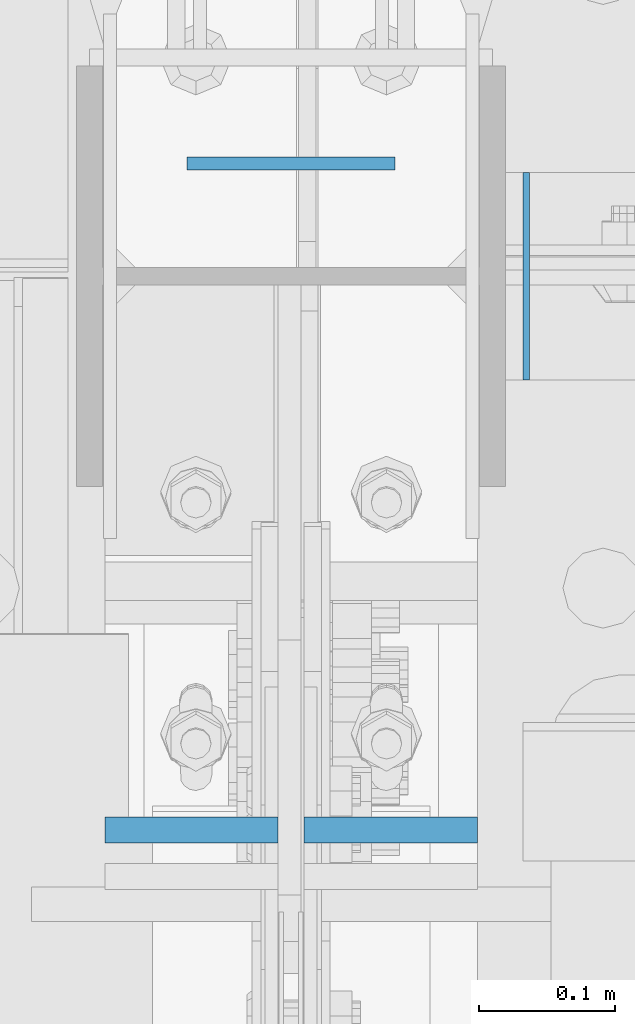
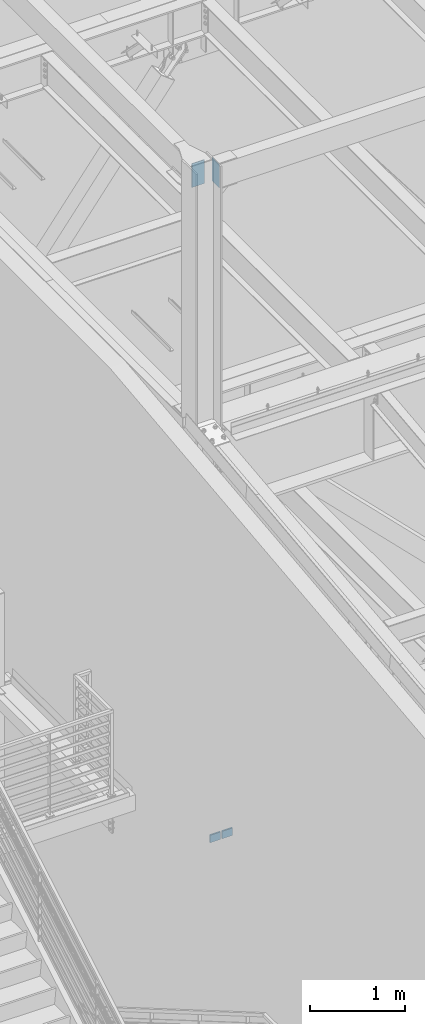
# One storey, part 489 of 1179: 4 columns, 4 elements without a shape of their own.
"""IFC2X3 building model written with IfcOpenShell, lengths in millimetres."""

from ifc_helpers import new_model, si_unit, frame, origin_with_axes, place, context, subcontext, project, spatial, faceted_brep, material, type_object, element, aggregate, save


model = new_model("IFC2X3")

# Units and contexts
model_context = context("Model", 3, precision=1e-05, world=origin_with_axes())
body_context = subcontext(model_context, "Body", "Model", "MODEL_VIEW")
ifc_project = project(units=[si_unit("LENGTHUNIT", "METRE", prefix="MILLI"), si_unit("AREAUNIT", "SQUARE_METRE"), si_unit("VOLUMEUNIT", "CUBIC_METRE"), si_unit("MASSUNIT", "GRAM", prefix="KILO"), si_unit("TIMEUNIT", "SECOND"), si_unit("PLANEANGLEUNIT", "RADIAN"), si_unit("SOLIDANGLEUNIT", "STERADIAN"), si_unit("THERMODYNAMICTEMPERATUREUNIT", "DEGREE_CELSIUS"), si_unit("LUMINOUSINTENSITYUNIT", "LUMEN")], contexts=[model_context])

# Site, building, storey
site_placement = place(None, origin_with_axes())
site = spatial("IfcSite", under=ifc_project, at=site_placement, CompositionType="ELEMENT")
building_placement = place(site_placement, origin_with_axes())
building = spatial("IfcBuilding", under=site, at=building_placement, Name="Undefined", CompositionType="ELEMENT")
storey_placement = place(building_placement, origin_with_axes())
storey = spatial("IfcBuildingStorey", under=building, at=storey_placement, Name="Undefined", CompositionType="ELEMENT", Elevation=0.0)

# Assembly, column
assembly_1_placement = place(storey_placement, origin_with_axes())
assembly_1 = element("IfcElementAssembly", 1, at=assembly_1_placement, inside=storey, Name="BEAM", AssemblyPlace="NOTDEFINED", PredefinedType="RIGID_FRAME")
ifc_material_1 = material(Name="STEEL/A36")
column_type_1 = type_object("IfcColumnType", PredefinedType="NOTDEFINED")
column_1_placement = place(assembly_1_placement, frame((431.8, 34474.1500000406, 16122.65), z_axis=(1.0, 0.0, 0.0), x_axis=(0.0, 0.0, 1.0)))
column_1 = element("IfcColumn", 2, at=column_1_placement, type_object=column_type_1, material=ifc_material_1, Name="PLATE", context=body_context, shape_type="Brep", body=[
    faceted_brep([(0.0, 4.76249999999982, -76.1999999999971), (0.0, 4.76249999999982, 76.1999999999971), (304.799999999999, 4.76250000000073, 76.1999999999971), (304.799999999999, 4.76250000000073, -76.1999999999971), (0.0, -4.76249999999982, 76.1999999999971), (304.799999999999, -4.76250000000073, 76.1999999999971), (0.0, -4.76249999999982, -76.1999999999971), (304.799999999999, -4.76250000000073, -76.1999999999971)], [[[0, 1, 2, 3]], [[1, 4, 5, 2]], [[4, 6, 7, 5]], [[6, 0, 3, 7]], [[5, 7, 3, 2]], [[6, 4, 1, 0]]]),
])
aggregate(assembly_1, [column_1])

assembly_2_placement = place(storey_placement, origin_with_axes())
assembly_2 = element("IfcElementAssembly", 3, at=assembly_2_placement, inside=storey, Name="PLATE", AssemblyPlace="NOTDEFINED", PredefinedType="RIGID_FRAME")
ifc_material_2 = material(Name="STEEL/A572-GR.50")
column_type_2 = type_object("IfcColumnType", PredefinedType="NOTDEFINED")
column_2_placement = place(assembly_2_placement, frame((358.774999999999, 33985.8157935486, 8013.69998747746), z_axis=(-1.0, 0.0, 0.0), x_axis=(0.0, 0.0, 1.0)))
column_2 = element("IfcColumn", 4, at=column_2_placement, type_object=column_type_2, material=ifc_material_2, Name="PLATE", context=body_context, shape_type="Brep", body=[
    faceted_brep([(0.0, 9.52500000000146, -63.5), (0.0, 9.52500000000146, 63.5), (96.3870800008062, 9.52500000000146, 63.5), (96.3870800008062, 9.52500000000146, -63.5), (0.0, -9.52500000000146, 63.5), (96.3870800008062, -9.52500000000146, 63.5), (0.0, -9.52500000000146, -63.5), (96.3870800008062, -9.52500000000146, -63.5)], [[[0, 1, 2, 3]], [[1, 4, 5, 2]], [[4, 6, 7, 5]], [[6, 0, 3, 7]], [[5, 7, 3, 2]], [[6, 4, 1, 0]]]),
])
aggregate(assembly_2, [column_2])

assembly_3_placement = place(storey_placement, origin_with_axes())
assembly_3 = element("IfcElementAssembly", 5, at=assembly_3_placement, inside=storey, Name="PLATE", AssemblyPlace="NOTDEFINED", PredefinedType="RIGID_FRAME")
column_3_placement = place(assembly_3_placement, frame((504.824999999999, 33985.8157935486, 8013.69998747746), z_axis=(-1.0, 0.0, 0.0), x_axis=(0.0, 0.0, 1.0)))
column_3 = element("IfcColumn", 6, at=column_3_placement, type_object=column_type_2, material=ifc_material_2, Name="PLATE", context=body_context, shape_type="Brep", body=[
    faceted_brep([(0.0, 9.52500000000146, -63.5), (0.0, 9.52500000000146, 63.5), (96.3870800008062, 9.52500000000146, 63.5), (96.3870800008062, 9.52500000000146, -63.5), (0.0, -9.52500000000146, 63.5), (96.3870800008062, -9.52500000000146, 63.5), (0.0, -9.52500000000146, -63.5), (96.3870800008062, -9.52500000000146, -63.5)], [[[0, 1, 2, 3]], [[1, 4, 5, 2]], [[4, 6, 7, 5]], [[6, 0, 3, 7]], [[5, 7, 3, 2]], [[6, 4, 1, 0]]]),
])
aggregate(assembly_3, [column_3])

assembly_4_placement = place(storey_placement, origin_with_axes())
assembly_4 = element("IfcElementAssembly", 7, at=assembly_4_placement, inside=storey, Name="BEAM", AssemblyPlace="NOTDEFINED", PredefinedType="RIGID_FRAME")
column_type_3 = type_object("IfcColumnType", PredefinedType="NOTDEFINED")
column_4_placement = place(assembly_4_placement, frame((604.0435, 34391.6, 16122.65), z_axis=(0.0, -1.0, 0.0), x_axis=(0.0, 0.0, 1.0)))
column_4 = element("IfcColumn", 8, at=column_4_placement, type_object=column_type_3, material=ifc_material_1, Name="PLATE", context=body_context, shape_type="Brep", body=[
    faceted_brep([(0.0, 2.38150000000041, -76.1999999999998), (0.0, 2.38150000000041, 76.1999999999998), (304.799999999999, 2.38150000000314, 76.2), (304.799999999999, 2.38150000000314, -76.2), (0.0, -2.38150000000041, 76.1999999999998), (304.799999999999, -2.38150000000314, 76.2), (0.0, -2.38150000000041, -76.1999999999998), (304.799999999999, -2.38150000000314, -76.2)], [[[0, 1, 2, 3]], [[1, 4, 5, 2]], [[4, 6, 7, 5]], [[6, 0, 3, 7]], [[5, 7, 3, 2]], [[6, 4, 1, 0]]]),
])
aggregate(assembly_4, [column_4])

save(model, "model.ifc")
